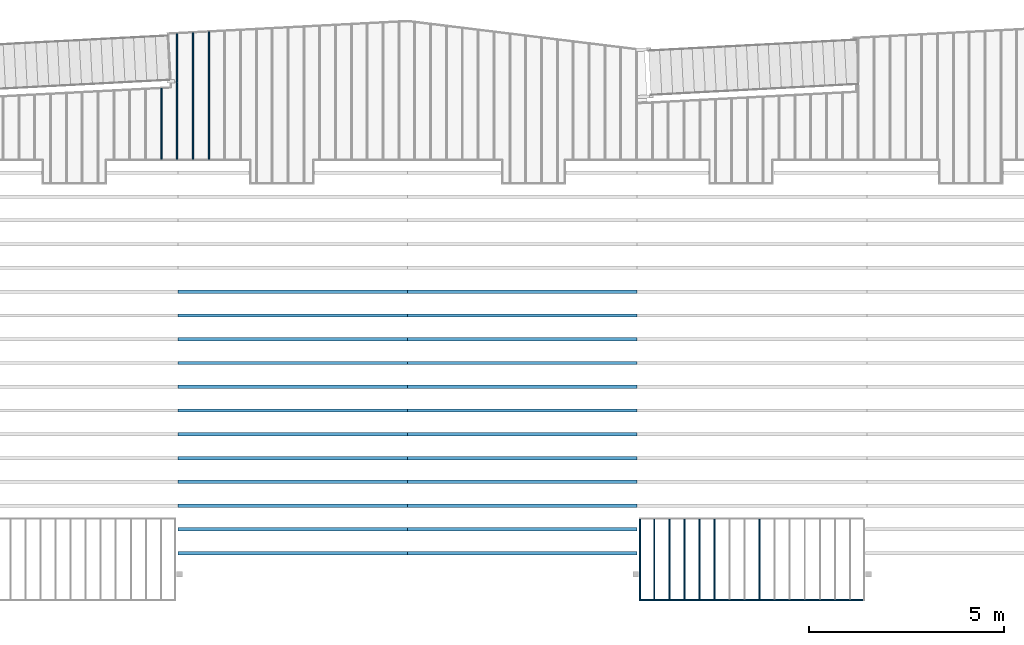
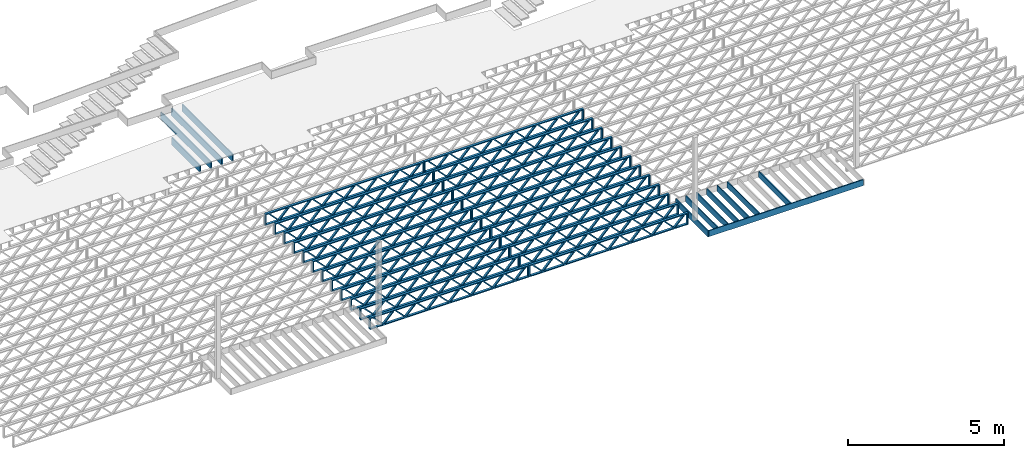
# One storey, part 6 of 23: 36 beams, 4 elements without a shape of their own.
"""IFC4 building model written with IfcOpenShell, lengths in feet."""

import ifcopenshell
import ifcopenshell.guid

model = None  # the IFC model being written
_history = None  # IfcOwnerHistory: only IFC2X3 demands one
_inside = {}  # id of a spatial element -> (the spatial element, [elements in it])
_under = {}  # id of a project, library or spatial element -> (it, [spatial elements below it])
_declared = {}  # id of a project -> (the project, [libraries it declares])
_typed = {}  # id of a type object -> (the type object, [elements of that type])
_made_of = {}  # id of a material, layer set ... -> (it, [elements and type objects made of it])


def new_model(schema):
    """Start an empty IFC model of exactly this schema.

    Asked for "IFC4X3", IfcOpenShell would pick the latest addendum, in which some entities
    have other attributes; the version numbers below select the first issue.
    IFC2X3 requires an IfcOwnerHistory on every rooted entity: one is made here for all.
    """
    global model, _history
    if schema == "IFC4X3":
        model = ifcopenshell.file(schema_version=(4, 3, 0, 0))
    else:
        model = ifcopenshell.file(schema=schema)
    _inside.clear()
    _under.clear()
    _declared.clear()
    _typed.clear()
    _made_of.clear()
    _history = None
    if model.schema == "IFC2X3":
        org = make("IfcOrganization", Name="unknown")
        user = make(
            "IfcPersonAndOrganization",
            ThePerson=make("IfcPerson", FamilyName="unknown"),
            TheOrganization=org,
        )
        app = make(
            "IfcApplication",
            ApplicationDeveloper=org,
            Version="unknown",
            ApplicationFullName="unknown",
            ApplicationIdentifier="unknown",
        )
        _history = make(
            "IfcOwnerHistory",
            OwningUser=user,
            OwningApplication=app,
            ChangeAction="ADDED",
            CreationDate=0,
        )
    return model


def make(cls, **values):
    """One entity of the class cls with the attributes given. An attribute that is None is left unset."""
    return model.create_entity(
        cls, **{name: value for name, value in values.items() if value is not None}
    )


def entity(cls, *values):
    """Any entity or typed value of the class cls, its attributes in the order of the schema. None: left unset."""
    e = model.create_entity(cls)
    for i, value in enumerate(values):
        if value is not None:
            e[i] = value
    return e


def rooted(cls, **values):
    """An entity with a GlobalId (a new one), such as an element, a storey or a relation."""
    return make(cls, GlobalId=ifcopenshell.guid.new(), OwnerHistory=_history, **values)


def si_unit(unit_type, name, prefix=None):
    """IfcSIUnit, for example si_unit("LENGTHUNIT", "METRE", prefix="MILLI")."""
    return make("IfcSIUnit", UnitType=unit_type, Prefix=prefix, Name=name)


def converted_unit(unit_type, name, factor, base, dimensions=None, offset=None):
    """IfcConversionBasedUnit, such as the inch: factor (a typed value) times the base unit."""
    return make(
        "IfcConversionBasedUnit"
        if offset is None
        else "IfcConversionBasedUnitWithOffset",
        ConversionOffset=offset,
        Dimensions=None
        if dimensions is None
        else entity("IfcDimensionalExponents", *dimensions),
        UnitType=unit_type,
        Name=name,
        ConversionFactor=make(
            "IfcMeasureWithUnit", ValueComponent=factor, UnitComponent=base
        ),
    )


def derived_unit(unit_type, elements):
    """IfcDerivedUnit: a product of units, each with its exponent."""
    return make(
        "IfcDerivedUnit",
        Elements=[
            make("IfcDerivedUnitElement", Unit=unit, Exponent=power)
            for unit, power in elements
        ],
        UnitType=unit_type,
    )


def assignment(units):
    """IfcUnitAssignment: the units of a project."""
    return None if units is None else make("IfcUnitAssignment", Units=units)


def point(xyz):
    """IfcCartesianPoint."""
    return None if xyz is None else make("IfcCartesianPoint", Coordinates=xyz)


def direction(xyz):
    """IfcDirection."""
    return None if xyz is None else make("IfcDirection", DirectionRatios=xyz)


def frame(location, z_axis=None, x_axis=None):
    """IfcAxis2Placement3D, a coordinate frame: its origin and axes. An axis left out is left unset."""
    return make(
        "IfcAxis2Placement3D",
        Location=point(location),
        Axis=direction(z_axis),
        RefDirection=direction(x_axis),
    )


def frame_2d(location, x_axis=None):
    """IfcAxis2Placement2D, a coordinate frame in the plane: its origin and x axis."""
    return make(
        "IfcAxis2Placement2D", Location=point(location), RefDirection=direction(x_axis)
    )


def origin():
    """The frame at (0, 0, 0) with its axes left unset."""
    return frame((0.0, 0.0, 0.0))


def origin_2d_with_axis():
    """The frame at (0, 0) in the plane with the x axis (1, 0) written out."""
    return frame_2d((0.0, 0.0), x_axis=(1.0, 0.0))


def place(relative_to, where):
    """IfcLocalPlacement: puts the frame where relative to a parent placement (None: the world)."""
    return make(
        "IfcLocalPlacement", PlacementRelTo=relative_to, RelativePlacement=where
    )


def context(
    kind, dimensions, precision=None, world=None, true_north=None, identifier=None
):
    """IfcGeometricRepresentationContext, for example the 3D "Model" context."""
    return make(
        "IfcGeometricRepresentationContext",
        ContextIdentifier=identifier,
        ContextType=kind,
        CoordinateSpaceDimension=dimensions,
        Precision=precision,
        WorldCoordinateSystem=world,
        TrueNorth=true_north,
    )


def subcontext(parent, identifier, kind, view, scale=None):
    """IfcGeometricRepresentationSubContext, for example "Body" below "Model"."""
    return make(
        "IfcGeometricRepresentationSubContext",
        ContextIdentifier=identifier,
        ContextType=kind,
        ParentContext=parent,
        TargetScale=scale,
        TargetView=view,
    )


def project(units=None, contexts=None):
    """IfcProject with its units and contexts."""
    return rooted(
        "IfcProject",
        Name="project",
        RepresentationContexts=contexts,
        UnitsInContext=assignment(units),
    )


def spatial(cls, under=None, at=None, **own):
    """A site, building, storey or space (cls), placed at a placement, below another one or the project."""
    s = rooted(cls, ObjectPlacement=at, **own)
    if under is not None:
        _under.setdefault(under.id(), (under, []))[1].append(s)
    return s


def profile(cls, at=None, kind="AREA", **sizes):
    """A parametric profile (cls). Its sizes go by their IFC names, for example OverallWidth=200.0."""
    return make(cls, ProfileType=kind, Position=at, **sizes)


def rectangle(**sizes):
    """IfcRectangleProfileDef."""
    return profile("IfcRectangleProfileDef", **sizes)


def extrude(swept, where, along, depth):
    """IfcExtrudedAreaSolid: the profile swept, set in the frame where, extruded along a direction by depth."""
    return make(
        "IfcExtrudedAreaSolid",
        SweptArea=swept,
        Position=where,
        ExtrudedDirection=direction(along),
        Depth=depth,
    )


def shape(context_of_items, identifier, shape_type, items):
    """IfcShapeRepresentation: the items that make up one representation, for example the "Body"."""
    return make(
        "IfcShapeRepresentation",
        ContextOfItems=context_of_items,
        RepresentationIdentifier=identifier,
        RepresentationType=shape_type,
        Items=items,
    )


def source(mapping_origin, context_of_items, identifier, shape_type, items):
    """IfcRepresentationMap: a shape defined once, which mapped items show again and again."""
    return make(
        "IfcRepresentationMap",
        MappingOrigin=mapping_origin,
        MappedRepresentation=shape(context_of_items, identifier, shape_type, items),
    )


def transform(
    local_origin,
    x_axis=None,
    y_axis=None,
    z_axis=None,
    scale=None,
    scale2=None,
    scale3=None,
    uniform=True,
):
    """IfcCartesianTransformationOperator3D, or its non-uniform kind. x_axis, y_axis, z_axis: its Axis1, 2, 3."""
    if uniform:
        return make(
            "IfcCartesianTransformationOperator3D",
            Axis1=direction(x_axis),
            Axis2=direction(y_axis),
            LocalOrigin=point(local_origin),
            Scale=scale,
            Axis3=direction(z_axis),
        )
    return make(
        "IfcCartesianTransformationOperator3DnonUniform",
        Axis1=direction(x_axis),
        Axis2=direction(y_axis),
        LocalOrigin=point(local_origin),
        Scale=scale,
        Axis3=direction(z_axis),
        Scale2=scale2,
        Scale3=scale3,
    )


def mapped(mapping_source, mapping_target):
    """IfcMappedItem: shows the shape of a source again, moved by a transform."""
    return make(
        "IfcMappedItem", MappingSource=mapping_source, MappingTarget=mapping_target
    )


def material(Name=None, Category=None):
    """IfcMaterial."""
    return make("IfcMaterial", Name=Name, Category=Category)


def material_profile(
    of_material, cross_section, Name=None, Category=None, Priority=None
):
    """IfcMaterialProfile: a cross section and its material."""
    return make(
        "IfcMaterialProfile",
        Name=Name,
        Material=of_material,
        Profile=cross_section,
        Priority=Priority,
        Category=Category,
    )


def profile_set(profiles, Name=None, composite=None):
    """IfcMaterialProfileSet."""
    return make(
        "IfcMaterialProfileSet",
        Name=Name,
        MaterialProfiles=profiles,
        CompositeProfile=composite,
    )


def profile_usage(for_profile_set, cardinal=None, extent=None):
    """IfcMaterialProfileSetUsage: how a profile set lies along its element."""
    return make(
        "IfcMaterialProfileSetUsage",
        ForProfileSet=for_profile_set,
        CardinalPoint=cardinal,
        ReferenceExtent=extent,
    )


def made_of(thing, what):
    """Note that an element or type object is made of a material, layer set ...; save() writes the relation."""
    if what is not None:
        _made_of.setdefault(what.id(), (what, []))[1].append(thing)
    return thing


def type_object(cls, material=None, **own):
    """A type object (cls), such as IfcWallType, which elements share."""
    return made_of(rooted(cls, **own), material)


def type_shapes(of_type, sources):
    """Give a type object the sources (RepresentationMaps) that its elements show as mapped items."""
    of_type.RepresentationMaps = sources


def element(
    cls,
    number,
    at=None,
    inside=None,
    cuts=None,
    type_object=None,
    material=None,
    context=None,
    identifier="Body",
    shape_type=None,
    held_by="IfcProductDefinitionShape",
    body=None,
    shapes=None,
    **own,
):
    """One element of the class cls, such as IfcWall. Its Tag is "e" and its number.

    at: its placement. inside: the storey or other place that contains it. cuts: it is an
    opening in that element (IfcRelVoidsElement). A single representation is given by context,
    identifier, shape_type and body (its items); several are given by shapes. held_by: the class
    of the entity that holds the representations. save() writes the other relations.
    """
    e = rooted(cls, Tag="e%d" % number, ObjectPlacement=at, **own)
    if body is not None:
        shapes = [shape(context, identifier, shape_type, body)]
    if shapes is not None:
        e.Representation = make(held_by, Representations=shapes)
    if inside is not None:
        _inside.setdefault(inside.id(), (inside, []))[1].append(e)
    if cuts is not None:
        rooted(
            "IfcRelVoidsElement", RelatingBuildingElement=cuts, RelatedOpeningElement=e
        )
    if type_object is not None:
        _typed.setdefault(type_object.id(), (type_object, []))[1].append(e)
    return made_of(e, material)


def aggregate(whole, parts):
    """IfcRelAggregates: a whole, such as a stair, and the parts it consists of."""
    return rooted("IfcRelAggregates", RelatingObject=whole, RelatedObjects=parts)


def save(model, path):
    """Write the relations noted so far, then the file.

    IfcRelAggregates (storeys below a building ...), IfcRelContainedInSpatialStructure (elements
    in a storey), IfcRelDefinesByType, IfcRelAssociatesMaterial and IfcRelDeclares: one each for
    every whole, place, type object, material and project.
    """
    for whole, parts in _under.values():
        aggregate(whole, parts)
    for where, things in _inside.values():
        rooted(
            "IfcRelContainedInSpatialStructure",
            RelatedElements=things,
            RelatingStructure=where,
        )
    for kind, things in _typed.values():
        rooted("IfcRelDefinesByType", RelatedObjects=things, RelatingType=kind)
    for what, things in _made_of.values():
        rooted("IfcRelAssociatesMaterial", RelatedObjects=things, RelatingMaterial=what)
    for by, libraries in _declared.values():
        rooted("IfcRelDeclares", RelatingContext=by, RelatedDefinitions=libraries)
    model.write(path)


model = new_model("IFC4")

# Units and contexts
model_context = context("Model", 3, precision=0.0001, world=origin(), true_north=direction((6.12303176911189e-17, 1.0)))
body_context = subcontext(model_context, "Body", "Model", "MODEL_VIEW")
ifc_project = project(units=[converted_unit("LENGTHUNIT", "FOOT", entity("IfcRatioMeasure", 0.3048), si_unit("LENGTHUNIT", "METRE"), dimensions=[1, 0, 0, 0, 0, 0, 0]), converted_unit("AREAUNIT", "SQUARE FOOT", entity("IfcRatioMeasure", 0.09290304), si_unit("AREAUNIT", "SQUARE_METRE"), dimensions=[2, 0, 0, 0, 0, 0, 0]), converted_unit("VOLUMEUNIT", "CUBIC FOOT", entity("IfcRatioMeasure", 0.028316846592), si_unit("VOLUMEUNIT", "CUBIC_METRE"), dimensions=[3, 0, 0, 0, 0, 0, 0]), converted_unit("PLANEANGLEUNIT", "DEGREE", entity("IfcRatioMeasure", 0.0174532925199433), si_unit("PLANEANGLEUNIT", "RADIAN"), dimensions=[0, 0, 0, 0, 0, 0, 0]), si_unit("MASSUNIT", "GRAM", prefix="KILO"), derived_unit("MASSDENSITYUNIT", [(si_unit("MASSUNIT", "GRAM", prefix="KILO"), 1), (si_unit("LENGTHUNIT", "METRE"), -3)]), derived_unit("MOMENTOFINERTIAUNIT", [(si_unit("LENGTHUNIT", "METRE"), 4)]), si_unit("TIMEUNIT", "SECOND"), si_unit("FREQUENCYUNIT", "HERTZ"), si_unit("THERMODYNAMICTEMPERATUREUNIT", "DEGREE_CELSIUS"), derived_unit("THERMALTRANSMITTANCEUNIT", [(si_unit("MASSUNIT", "GRAM", prefix="KILO"), 1), (si_unit("THERMODYNAMICTEMPERATUREUNIT", "KELVIN"), -1), (si_unit("TIMEUNIT", "SECOND"), -3)]), derived_unit("VOLUMETRICFLOWRATEUNIT", [(si_unit("LENGTHUNIT", "METRE"), 3), (si_unit("TIMEUNIT", "SECOND"), -1)]), si_unit("ELECTRICCURRENTUNIT", "AMPERE"), si_unit("ELECTRICVOLTAGEUNIT", "VOLT"), si_unit("POWERUNIT", "WATT"), si_unit("FORCEUNIT", "NEWTON"), si_unit("ILLUMINANCEUNIT", "LUX"), si_unit("LUMINOUSFLUXUNIT", "LUMEN"), si_unit("LUMINOUSINTENSITYUNIT", "CANDELA"), derived_unit("USERDEFINED", [(si_unit("MASSUNIT", "GRAM", prefix="KILO"), -1), (si_unit("LENGTHUNIT", "METRE"), -2), (si_unit("TIMEUNIT", "SECOND"), 3), (si_unit("LUMINOUSFLUXUNIT", "LUMEN"), 1)]), derived_unit("LINEARVELOCITYUNIT", [(si_unit("LENGTHUNIT", "METRE"), 1), (si_unit("TIMEUNIT", "SECOND"), -1)]), si_unit("PRESSUREUNIT", "PASCAL"), derived_unit("USERDEFINED", [(si_unit("LENGTHUNIT", "METRE"), -2), (si_unit("MASSUNIT", "GRAM", prefix="KILO"), 1), (si_unit("TIMEUNIT", "SECOND"), -2)]), derived_unit("LINEARFORCEUNIT", [(si_unit("MASSUNIT", "GRAM", prefix="KILO"), 1), (si_unit("LENGTHUNIT", "METRE"), 1), (si_unit("TIMEUNIT", "SECOND"), -2), (si_unit("LENGTHUNIT", "METRE"), -1)]), derived_unit("PLANARFORCEUNIT", [(si_unit("MASSUNIT", "GRAM", prefix="KILO"), 1), (si_unit("LENGTHUNIT", "METRE"), 1), (si_unit("TIMEUNIT", "SECOND"), -2), (si_unit("LENGTHUNIT", "METRE"), -2)])], contexts=[model_context])

# Site, building, storey
site_placement = place(None, origin())
site = spatial("IfcSite", under=ifc_project, at=site_placement, CompositionType="ELEMENT")
building_placement = place(site_placement, origin())
building = spatial("IfcBuilding", under=site, at=building_placement, CompositionType="ELEMENT")
storey_placement = place(building_placement, frame((0.0, 0.0, 10.8020833333333)))
storey = spatial("IfcBuildingStorey", under=building, at=storey_placement, Name="2ND FLOOR", CompositionType="ELEMENT", Elevation=10.8020833333333)

# Assembly, beams
assembly_1_placement = place(storey_placement, origin())
assembly_1 = element("IfcElementAssembly", 1, at=assembly_1_placement, inside=storey, Name="Structural Beam System:Structural Framing System", ObjectType="Structural Beam System:Structural Framing System", AssemblyPlace="NOTDEFINED", PredefinedType="BEAM_GRID")
ifc_material_1 = material(Category="Materials")
ifc_material_profile_1 = material_profile(ifc_material_1, rectangle(XDim=0.770833333333333, YDim=0.124999999999994, at=frame_2d((-5.55111512312578e-17, 0.0), x_axis=(1.0, 0.0))))
ifc_profile_set_1 = profile_set([ifc_material_profile_1])
ifc_profile_usage_1 = profile_usage(ifc_profile_set_1, cardinal=8)
beam_type_1 = type_object("IfcBeamType", PredefinedType="BEAM", material=ifc_profile_set_1)
shared_shape_1 = source(origin(), body_context, "Body", "SweptSolid", [
    extrude(rectangle(XDim=0.770833333333333, YDim=0.124999999999994, at=frame_2d((-5.55111512312578e-17, 0.0), x_axis=(1.0, 0.0))), frame((-3.35416666666737, 0.0, 0.0), z_axis=(1.0, 0.0, 0.0), x_axis=(0.0, 0.0, -1.0)), (0.0, 0.0, 1.0), 6.70833333333462),
])
type_shapes(beam_type_1, [shared_shape_1])
beam_1_placement = place(assembly_1_placement, frame((-173.43642510598, 925.341101549317, -0.645833333333471), z_axis=(0.0, 0.0, 1.0), x_axis=(0.0, 1.0, 0.0)))
beam_1 = element("IfcBeam", 2, at=beam_1_placement, type_object=beam_type_1, material=ifc_profile_usage_1, PredefinedType="BEAM", context=body_context, shape_type="MappedRepresentation", body=[
    mapped(shared_shape_1, transform((0.0, 0.0, 0.0), scale=1.0)),
])
ifc_profile_usage_2 = profile_usage(ifc_profile_set_1, cardinal=8)
beam_2_placement = place(assembly_1_placement, frame((-177.237076147655, 925.341101549318, -0.645833333333471), z_axis=(0.0, 0.0, 1.0), x_axis=(0.0, 1.0, 0.0)))
beam_2 = element("IfcBeam", 3, at=beam_2_placement, type_object=beam_type_1, material=ifc_profile_usage_2, PredefinedType="BEAM", context=body_context, shape_type="MappedRepresentation", body=[
    mapped(shared_shape_1, transform((0.0, 0.0, 0.0), scale=1.0)),
])
ifc_profile_usage_3 = profile_usage(ifc_profile_set_1, cardinal=8)
beam_3_placement = place(assembly_1_placement, frame((-178.503959828213, 925.341101549318, -0.645833333333471), z_axis=(0.0, 0.0, 1.0), x_axis=(0.0, 1.0, 0.0)))
beam_3 = element("IfcBeam", 4, at=beam_3_placement, type_object=beam_type_1, material=ifc_profile_usage_3, PredefinedType="BEAM", context=body_context, shape_type="MappedRepresentation", body=[
    mapped(shared_shape_1, transform((0.0, 0.0, 0.0), scale=1.0)),
])
ifc_profile_usage_4 = profile_usage(ifc_profile_set_1, cardinal=8)
beam_4_placement = place(assembly_1_placement, frame((-179.770843508771, 925.341101549318, -0.645833333333471), z_axis=(0.0, 0.0, 1.0), x_axis=(0.0, 1.0, 0.0)))
beam_4 = element("IfcBeam", 5, at=beam_4_placement, type_object=beam_type_1, material=ifc_profile_usage_4, PredefinedType="BEAM", context=body_context, shape_type="MappedRepresentation", body=[
    mapped(shared_shape_1, transform((0.0, 0.0, 0.0), scale=1.0)),
])
ifc_profile_usage_5 = profile_usage(ifc_profile_set_1, cardinal=8)
beam_5_placement = place(assembly_1_placement, frame((-181.03772718933, 925.341101549318, -0.645833333333471), z_axis=(0.0, 0.0, 1.0), x_axis=(0.0, 1.0, 0.0)))
beam_5 = element("IfcBeam", 6, at=beam_5_placement, type_object=beam_type_1, material=ifc_profile_usage_5, PredefinedType="BEAM", context=body_context, shape_type="MappedRepresentation", body=[
    mapped(shared_shape_1, transform((0.0, 0.0, 0.0), scale=1.0)),
])
ifc_profile_usage_6 = profile_usage(ifc_profile_set_1, cardinal=8)
beam_6_placement = place(assembly_1_placement, frame((-182.304610869888, 925.341101549319, -0.645833333333471), z_axis=(0.0, 0.0, 1.0), x_axis=(0.0, 1.0, 0.0)))
beam_6 = element("IfcBeam", 7, at=beam_6_placement, type_object=beam_type_1, material=ifc_profile_usage_6, PredefinedType="BEAM", context=body_context, shape_type="MappedRepresentation", body=[
    mapped(shared_shape_1, transform((0.0, 0.0, 0.0), scale=1.0)),
])
aggregate(assembly_1, [beam_1, beam_2, beam_3, beam_4, beam_5, beam_6])

assembly_2_placement = place(storey_placement, origin())
assembly_2 = element("IfcElementAssembly", 8, at=assembly_2_placement, inside=storey, Name="Structural Beam System:Structural Framing System", ObjectType="Structural Beam System:Structural Framing System", AssemblyPlace="NOTDEFINED", PredefinedType="BEAM_GRID")
ifc_material_2 = material(Name="WOOD TRUSS", Category="Materials")
ifc_material_profile_2 = material_profile(ifc_material_2, rectangle(XDim=1.73473973950632, YDim=0.125, at=frame_2d((-1.11022302462516e-16, 8.32667268468867e-17), x_axis=(1.0, 0.0))))
ifc_material_profile_3 = material_profile(ifc_material_2, rectangle(XDim=1.73473973950633, YDim=0.125, at=frame_2d((-1.11022302462516e-16, 8.32667268468867e-17), x_axis=(1.0, 0.0))))
ifc_material_profile_4 = material_profile(ifc_material_2, rectangle(XDim=1.73473973950632, YDim=0.125, at=frame_2d((-5.55111512312578e-17, 1.38777878078145e-16), x_axis=(1.0, 0.0))))
ifc_material_profile_5 = material_profile(ifc_material_2, rectangle(XDim=1.73473973950633, YDim=0.125, at=frame_2d((-1.11022302462516e-16, 8.32667268468867e-17), x_axis=(1.0, 0.0))))
ifc_material_profile_6 = material_profile(ifc_material_2, rectangle(XDim=1.73473973950632, YDim=0.125, at=frame_2d((-1.11022302462516e-16, 8.32667268468867e-17), x_axis=(1.0, 0.0))))
ifc_material_profile_7 = material_profile(ifc_material_2, rectangle(XDim=1.73473973950633, YDim=0.125, at=frame_2d((-2.77555756156289e-16, 3.05311331771918e-16), x_axis=(1.0, 0.0))))
ifc_material_profile_8 = material_profile(ifc_material_2, rectangle(XDim=1.73473973950632, YDim=0.124999999999999, at=frame_2d((-3.88578058618805e-16, -2.4980018054066e-16), x_axis=(1.0, 0.0))))
ifc_material_profile_9 = material_profile(ifc_material_2, rectangle(XDim=1.73473973950633, YDim=0.125, at=frame_2d((2.77555756156289e-16, -3.05311331771918e-16), x_axis=(1.0, 0.0))))
ifc_material_profile_10 = material_profile(ifc_material_2, rectangle(XDim=1.73473973950632, YDim=0.124999999999999, at=frame_2d((-1.11022302462516e-16, 8.32667268468867e-17), x_axis=(1.0, 0.0))))
ifc_material_profile_11 = material_profile(ifc_material_2, rectangle(XDim=1.73473973950633, YDim=0.125, at=origin_2d_with_axis()))
ifc_material_profile_12 = material_profile(ifc_material_2, rectangle(XDim=0.124999999999982, YDim=0.291666666666668, at=origin_2d_with_axis()))
ifc_material_profile_13 = material_profile(ifc_material_2, rectangle(XDim=0.124999999999932, YDim=0.291666666666664, at=origin_2d_with_axis()))
ifc_material_profile_14 = material_profile(ifc_material_2, rectangle(XDim=1.25000000000002, YDim=0.29166666666667, at=origin_2d_with_axis()))
ifc_material_profile_15 = material_profile(ifc_material_2, rectangle(XDim=1.25000000000004, YDim=0.291666666666667, at=origin_2d_with_axis()))
ifc_profile_set_2 = profile_set([ifc_material_profile_2, ifc_material_profile_3, ifc_material_profile_4, ifc_material_profile_5, ifc_material_profile_6, ifc_material_profile_7, ifc_material_profile_8, ifc_material_profile_9, ifc_material_profile_10, ifc_material_profile_11, ifc_material_profile_12, ifc_material_profile_13, ifc_material_profile_14, ifc_material_profile_15])
ifc_profile_usage_7 = profile_usage(ifc_profile_set_2, cardinal=8)
beam_type_2 = type_object("IfcBeamType", PredefinedType="BEAM", material=ifc_profile_set_2)
shared_shape_2 = source(origin(), body_context, "Body", "SweptSolid", [
    extrude(rectangle(XDim=1.73473973950632, YDim=0.124999999999999, at=frame_2d((5.55111512312578e-16, 7.21644966006352e-16), x_axis=(1.0, 0.0))), frame((5.95847627016997, -0.145833333333334, 0.0), z_axis=(0.0, 1.0, 0.0), x_axis=(0.693383046997606, 0.0, 0.720569184836762)), (0.0, 0.0, 1.0), 0.291666666666667),
    extrude(rectangle(XDim=1.73473973950633, YDim=0.125, at=origin_2d_with_axis()), frame((4.7081903964967, -0.145833333333334, 0.0), z_axis=(0.0, 1.0, 0.0), x_axis=(0.69338304699761, 0.0, -0.720569184836758)), (0.0, 0.0, 1.0), 0.291666666666666),
    extrude(rectangle(XDim=1.73473973950632, YDim=0.125, at=frame_2d((2.22044604925031e-16, 3.88578058618805e-16), x_axis=(1.0, 0.0))), frame((3.29180960350347, -0.145833333333334, 0.0), z_axis=(0.0, 1.0, 0.0), x_axis=(0.693383046997606, 0.0, 0.720569184836762)), (0.0, 0.0, 1.0), 0.291666666666667),
    extrude(rectangle(XDim=1.73473973950633, YDim=0.125, at=frame_2d((1.11022302462516e-16, -8.32667268468867e-17), x_axis=(1.0, 0.0))), frame((2.0415237298302, -0.145833333333334, 0.0), z_axis=(0.0, 1.0, 0.0), x_axis=(0.69338304699761, 0.0, -0.720569184836758)), (0.0, 0.0, 1.0), 0.291666666666667),
    extrude(rectangle(XDim=1.73473973950632, YDim=0.125, at=frame_2d((-5.55111512312578e-17, 1.38777878078145e-16), x_axis=(1.0, 0.0))), frame((0.625142936836964, -0.145833333333334, 0.0), z_axis=(0.0, 1.0, 0.0), x_axis=(0.693383046997606, 0.0, 0.720569184836762)), (0.0, 0.0, 1.0), 0.291666666666667),
    extrude(rectangle(XDim=1.73473973950633, YDim=0.125, at=frame_2d((-1.11022302462516e-16, 8.32667268468867e-17), x_axis=(1.0, 0.0))), frame((-0.625142936836306, -0.145833333333334, 0.0), z_axis=(0.0, 1.0, 0.0), x_axis=(0.69338304699761, 0.0, -0.720569184836758)), (0.0, 0.0, 1.0), 0.291666666666667),
    extrude(rectangle(XDim=1.73473973950632, YDim=0.125, at=frame_2d((-1.11022302462516e-16, 8.32667268468867e-17), x_axis=(1.0, 0.0))), frame((-2.04152372982954, -0.145833333333334, 0.0), z_axis=(0.0, 1.0, 0.0), x_axis=(0.693383046997606, 0.0, 0.720569184836762)), (0.0, 0.0, 1.0), 0.291666666666667),
    extrude(rectangle(XDim=1.73473973950633, YDim=0.125, at=origin_2d_with_axis()), frame((-3.29180960350281, -0.145833333333334, 0.0), z_axis=(0.0, 1.0, 0.0), x_axis=(0.69338304699761, 0.0, -0.720569184836758)), (0.0, 0.0, 1.0), 0.291666666666667),
    extrude(rectangle(XDim=1.73473973950632, YDim=0.124999999999999, at=frame_2d((-1.11022302462516e-16, 8.32667268468867e-17), x_axis=(1.0, 0.0))), frame((-4.70819039649604, -0.145833333333334, 0.0), z_axis=(0.0, 1.0, 0.0), x_axis=(0.693383046997606, 0.0, 0.720569184836762)), (0.0, 0.0, 1.0), 0.291666666666667),
    extrude(rectangle(XDim=1.73473973950633, YDim=0.125, at=frame_2d((-5.55111512312578e-16, 6.38378239159465e-16), x_axis=(1.0, 0.0))), frame((-5.95847627016931, -0.145833333333334, 0.0), z_axis=(0.0, 1.0, 0.0), x_axis=(0.69338304699761, 0.0, -0.720569184836758)), (0.0, 0.0, 1.0), 0.291666666666666),
    extrude(rectangle(XDim=1.73473973950632, YDim=0.125, at=frame_2d((-7.21644966006352e-16, -5.82867087928207e-16), x_axis=(1.0, 0.0))), frame((8.62514293683647, -0.145833333333334, 0.0), z_axis=(0.0, 1.0, 0.0), x_axis=(0.693383046997607, 0.0, 0.720569184836761)), (0.0, 0.0, 1.0), 0.291666666666667),
    extrude(rectangle(XDim=1.73473973950633, YDim=0.125, at=origin_2d_with_axis()), frame((7.3748570631632, -0.145833333333334, 0.0), z_axis=(0.0, 1.0, 0.0), x_axis=(0.69338304699761, 0.0, -0.720569184836758)), (0.0, 0.0, 1.0), 0.291666666666666),
    extrude(rectangle(XDim=1.73473973950632, YDim=0.124999999999999, at=frame_2d((-1.11022302462516e-16, 8.32667268468867e-17), x_axis=(1.0, 0.0))), frame((-7.37485706316255, -0.145833333333334, 0.0), z_axis=(0.0, 1.0, 0.0), x_axis=(0.693383046997606, 0.0, 0.720569184836762)), (0.0, 0.0, 1.0), 0.291666666666667),
    extrude(rectangle(XDim=1.73473973950633, YDim=0.125, at=origin_2d_with_axis()), frame((-8.62514293683582, -0.145833333333334, 0.0), z_axis=(0.0, 1.0, 0.0), x_axis=(0.69338304699761, 0.0, -0.720569184836758)), (0.0, 0.0, 1.0), 0.291666666666666),
    extrude(rectangle(XDim=0.124999999999982, YDim=0.291666666666668, at=origin_2d_with_axis()), frame((-9.66666666666609, 0.0, 0.687500000000054), z_axis=(1.0, 0.0, 0.0), x_axis=(0.0, 0.0, -1.0)), (0.0, 0.0, 1.0), 19.3333333333322),
    extrude(rectangle(XDim=0.124999999999932, YDim=0.291666666666664, at=origin_2d_with_axis()), frame((-9.66666666666588, 0.0, -0.687499999999984), z_axis=(1.0, 0.0, 0.0), x_axis=(0.0, 0.0, -1.0)), (0.0, 0.0, 1.0), 19.333333333332),
    extrude(rectangle(XDim=1.25000000000002, YDim=0.29166666666667, at=origin_2d_with_axis()), frame((9.54166666666607, 0.0, 0.0), z_axis=(1.0, 0.0, 0.0), x_axis=(0.0, 0.0, -1.0)), (0.0, 0.0, 1.0), 0.12500000000002),
    extrude(rectangle(XDim=1.25000000000004, YDim=0.291666666666667, at=origin_2d_with_axis()), frame((-9.66666666666609, 0.0, 0.0), z_axis=(1.0, 0.0, 0.0), x_axis=(0.0, 0.0, -1.0)), (0.0, 0.0, 1.0), 0.125000000000023),
])
type_shapes(beam_type_2, [shared_shape_2])
beam_7_placement = place(assembly_2_placement, frame((-193.404827152229, 947.861934882651, -0.947916666666881)))
beam_7 = element("IfcBeam", 9, at=beam_7_placement, type_object=beam_type_2, material=ifc_profile_usage_7, PredefinedType="BEAM", context=body_context, shape_type="MappedRepresentation", body=[
    mapped(shared_shape_2, transform((0.0, 0.0, 0.0), scale=1.0)),
])
ifc_profile_usage_8 = profile_usage(ifc_profile_set_2, cardinal=8)
beam_8_placement = place(assembly_2_placement, frame((-193.404827152229, 945.861934882651, -0.947916666666881)))
beam_8 = element("IfcBeam", 10, at=beam_8_placement, type_object=beam_type_2, material=ifc_profile_usage_8, PredefinedType="BEAM", context=body_context, shape_type="MappedRepresentation", body=[
    mapped(shared_shape_2, transform((0.0, 0.0, 0.0), scale=1.0)),
])
ifc_profile_usage_9 = profile_usage(ifc_profile_set_2, cardinal=8)
beam_9_placement = place(assembly_2_placement, frame((-193.404827152229, 943.861934882651, -0.947916666666881)))
beam_9 = element("IfcBeam", 11, at=beam_9_placement, type_object=beam_type_2, material=ifc_profile_usage_9, PredefinedType="BEAM", context=body_context, shape_type="MappedRepresentation", body=[
    mapped(shared_shape_2, transform((0.0, 0.0, 0.0), scale=1.0)),
])
ifc_profile_usage_10 = profile_usage(ifc_profile_set_2, cardinal=8)
beam_10_placement = place(assembly_2_placement, frame((-193.404827152229, 941.861934882651, -0.947916666666881)))
beam_10 = element("IfcBeam", 12, at=beam_10_placement, type_object=beam_type_2, material=ifc_profile_usage_10, PredefinedType="BEAM", context=body_context, shape_type="MappedRepresentation", body=[
    mapped(shared_shape_2, transform((0.0, 0.0, 0.0), scale=1.0)),
])
ifc_profile_usage_11 = profile_usage(ifc_profile_set_2, cardinal=8)
beam_11_placement = place(assembly_2_placement, frame((-193.404827152229, 939.861934882651, -0.947916666666881)))
beam_11 = element("IfcBeam", 13, at=beam_11_placement, type_object=beam_type_2, material=ifc_profile_usage_11, PredefinedType="BEAM", context=body_context, shape_type="MappedRepresentation", body=[
    mapped(shared_shape_2, transform((0.0, 0.0, 0.0), scale=1.0)),
])
ifc_profile_usage_12 = profile_usage(ifc_profile_set_2, cardinal=8)
beam_12_placement = place(assembly_2_placement, frame((-193.404827152229, 937.861934882651, -0.947916666666881)))
beam_12 = element("IfcBeam", 14, at=beam_12_placement, type_object=beam_type_2, material=ifc_profile_usage_12, PredefinedType="BEAM", context=body_context, shape_type="MappedRepresentation", body=[
    mapped(shared_shape_2, transform((0.0, 0.0, 0.0), scale=1.0)),
])
ifc_profile_usage_13 = profile_usage(ifc_profile_set_2, cardinal=8)
beam_13_placement = place(assembly_2_placement, frame((-193.404827152229, 935.861934882651, -0.947916666666881)))
beam_13 = element("IfcBeam", 15, at=beam_13_placement, type_object=beam_type_2, material=ifc_profile_usage_13, PredefinedType="BEAM", context=body_context, shape_type="MappedRepresentation", body=[
    mapped(shared_shape_2, transform((0.0, 0.0, 0.0), scale=1.0)),
])
ifc_profile_usage_14 = profile_usage(ifc_profile_set_2, cardinal=8)
beam_14_placement = place(assembly_2_placement, frame((-193.404827152229, 933.861934882651, -0.947916666666881)))
beam_14 = element("IfcBeam", 16, at=beam_14_placement, type_object=beam_type_2, material=ifc_profile_usage_14, PredefinedType="BEAM", context=body_context, shape_type="MappedRepresentation", body=[
    mapped(shared_shape_2, transform((0.0, 0.0, 0.0), scale=1.0)),
])
ifc_profile_usage_15 = profile_usage(ifc_profile_set_2, cardinal=8)
beam_15_placement = place(assembly_2_placement, frame((-193.404827152229, 931.861934882651, -0.947916666666881)))
beam_15 = element("IfcBeam", 17, at=beam_15_placement, type_object=beam_type_2, material=ifc_profile_usage_15, PredefinedType="BEAM", context=body_context, shape_type="MappedRepresentation", body=[
    mapped(shared_shape_2, transform((0.0, 0.0, 0.0), scale=1.0)),
])
ifc_profile_usage_16 = profile_usage(ifc_profile_set_2, cardinal=8)
beam_16_placement = place(assembly_2_placement, frame((-193.404827152229, 929.861934882651, -0.947916666666881)))
beam_16 = element("IfcBeam", 18, at=beam_16_placement, type_object=beam_type_2, material=ifc_profile_usage_16, PredefinedType="BEAM", context=body_context, shape_type="MappedRepresentation", body=[
    mapped(shared_shape_2, transform((0.0, 0.0, 0.0), scale=1.0)),
])
ifc_profile_usage_17 = profile_usage(ifc_profile_set_2, cardinal=8)
beam_17_placement = place(assembly_2_placement, frame((-193.404827152229, 927.861934882651, -0.947916666666881)))
beam_17 = element("IfcBeam", 19, at=beam_17_placement, type_object=beam_type_2, material=ifc_profile_usage_17, PredefinedType="BEAM", context=body_context, shape_type="MappedRepresentation", body=[
    mapped(shared_shape_2, transform((0.0, 0.0, 0.0), scale=1.0)),
])
ifc_profile_usage_18 = profile_usage(ifc_profile_set_2, cardinal=8)
beam_18_placement = place(assembly_2_placement, frame((-193.404827152229, 925.861934882651, -0.947916666666881)))
beam_18 = element("IfcBeam", 20, at=beam_18_placement, type_object=beam_type_2, material=ifc_profile_usage_18, PredefinedType="BEAM", context=body_context, shape_type="MappedRepresentation", body=[
    mapped(shared_shape_2, transform((0.0, 0.0, 0.0), scale=1.0)),
])
aggregate(assembly_2, [beam_7, beam_8, beam_9, beam_10, beam_11, beam_12, beam_13, beam_14, beam_15, beam_16, beam_17, beam_18])

assembly_3_placement = place(storey_placement, origin())
assembly_3 = element("IfcElementAssembly", 21, at=assembly_3_placement, inside=storey, Name="Structural Beam System:Structural Framing System", ObjectType="Structural Beam System:Structural Framing System", AssemblyPlace="NOTDEFINED", PredefinedType="BEAM_GRID")
ifc_profile_usage_19 = profile_usage(ifc_profile_set_2, cardinal=8)
beam_19_placement = place(assembly_3_placement, frame((-212.738160485495, 947.861934882651, -0.947916666666881), z_axis=(0.0, 0.0, 1.0), x_axis=(-1.0, 0.0, 0.0)))
beam_19 = element("IfcBeam", 22, at=beam_19_placement, type_object=beam_type_2, material=ifc_profile_usage_19, PredefinedType="BEAM", context=body_context, shape_type="MappedRepresentation", body=[
    mapped(shared_shape_2, transform((0.0, 0.0, 0.0), scale=1.0)),
])
ifc_profile_usage_20 = profile_usage(ifc_profile_set_2, cardinal=8)
beam_20_placement = place(assembly_3_placement, frame((-212.738160485495, 945.861934882651, -0.947916666666881), z_axis=(0.0, 0.0, 1.0), x_axis=(-1.0, 0.0, 0.0)))
beam_20 = element("IfcBeam", 23, at=beam_20_placement, type_object=beam_type_2, material=ifc_profile_usage_20, PredefinedType="BEAM", context=body_context, shape_type="MappedRepresentation", body=[
    mapped(shared_shape_2, transform((0.0, 0.0, 0.0), scale=1.0)),
])
ifc_profile_usage_21 = profile_usage(ifc_profile_set_2, cardinal=8)
beam_21_placement = place(assembly_3_placement, frame((-212.738160485495, 943.861934882651, -0.947916666666881), z_axis=(0.0, 0.0, 1.0), x_axis=(-1.0, 0.0, 0.0)))
beam_21 = element("IfcBeam", 24, at=beam_21_placement, type_object=beam_type_2, material=ifc_profile_usage_21, PredefinedType="BEAM", context=body_context, shape_type="MappedRepresentation", body=[
    mapped(shared_shape_2, transform((0.0, 0.0, 0.0), scale=1.0)),
])
ifc_profile_usage_22 = profile_usage(ifc_profile_set_2, cardinal=8)
beam_22_placement = place(assembly_3_placement, frame((-212.738160485495, 941.861934882651, -0.947916666666881), z_axis=(0.0, 0.0, 1.0), x_axis=(-1.0, 0.0, 0.0)))
beam_22 = element("IfcBeam", 25, at=beam_22_placement, type_object=beam_type_2, material=ifc_profile_usage_22, PredefinedType="BEAM", context=body_context, shape_type="MappedRepresentation", body=[
    mapped(shared_shape_2, transform((0.0, 0.0, 0.0), scale=1.0)),
])
ifc_profile_usage_23 = profile_usage(ifc_profile_set_2, cardinal=8)
beam_23_placement = place(assembly_3_placement, frame((-212.738160485495, 939.861934882651, -0.947916666666881), z_axis=(0.0, 0.0, 1.0), x_axis=(-1.0, 0.0, 0.0)))
beam_23 = element("IfcBeam", 26, at=beam_23_placement, type_object=beam_type_2, material=ifc_profile_usage_23, PredefinedType="BEAM", context=body_context, shape_type="MappedRepresentation", body=[
    mapped(shared_shape_2, transform((0.0, 0.0, 0.0), scale=1.0)),
])
ifc_profile_usage_24 = profile_usage(ifc_profile_set_2, cardinal=8)
beam_24_placement = place(assembly_3_placement, frame((-212.738160485495, 937.861934882651, -0.947916666666881), z_axis=(0.0, 0.0, 1.0), x_axis=(-1.0, 0.0, 0.0)))
beam_24 = element("IfcBeam", 27, at=beam_24_placement, type_object=beam_type_2, material=ifc_profile_usage_24, PredefinedType="BEAM", context=body_context, shape_type="MappedRepresentation", body=[
    mapped(shared_shape_2, transform((0.0, 0.0, 0.0), scale=1.0)),
])
ifc_profile_usage_25 = profile_usage(ifc_profile_set_2, cardinal=8)
beam_25_placement = place(assembly_3_placement, frame((-212.738160485495, 935.861934882651, -0.947916666666881), z_axis=(0.0, 0.0, 1.0), x_axis=(-1.0, 0.0, 0.0)))
beam_25 = element("IfcBeam", 28, at=beam_25_placement, type_object=beam_type_2, material=ifc_profile_usage_25, PredefinedType="BEAM", context=body_context, shape_type="MappedRepresentation", body=[
    mapped(shared_shape_2, transform((0.0, 0.0, 0.0), scale=1.0)),
])
ifc_profile_usage_26 = profile_usage(ifc_profile_set_2, cardinal=8)
beam_26_placement = place(assembly_3_placement, frame((-212.738160485495, 933.861934882651, -0.947916666666881), z_axis=(0.0, 0.0, 1.0), x_axis=(-1.0, 0.0, 0.0)))
beam_26 = element("IfcBeam", 29, at=beam_26_placement, type_object=beam_type_2, material=ifc_profile_usage_26, PredefinedType="BEAM", context=body_context, shape_type="MappedRepresentation", body=[
    mapped(shared_shape_2, transform((0.0, 0.0, 0.0), scale=1.0)),
])
ifc_profile_usage_27 = profile_usage(ifc_profile_set_2, cardinal=8)
beam_27_placement = place(assembly_3_placement, frame((-212.738160485495, 931.861934882651, -0.947916666666881), z_axis=(0.0, 0.0, 1.0), x_axis=(-1.0, 0.0, 0.0)))
beam_27 = element("IfcBeam", 30, at=beam_27_placement, type_object=beam_type_2, material=ifc_profile_usage_27, PredefinedType="BEAM", context=body_context, shape_type="MappedRepresentation", body=[
    mapped(shared_shape_2, transform((0.0, 0.0, 0.0), scale=1.0)),
])
ifc_profile_usage_28 = profile_usage(ifc_profile_set_2, cardinal=8)
beam_28_placement = place(assembly_3_placement, frame((-212.738160485495, 929.861934882651, -0.947916666666881), z_axis=(0.0, 0.0, 1.0), x_axis=(-1.0, 0.0, 0.0)))
beam_28 = element("IfcBeam", 31, at=beam_28_placement, type_object=beam_type_2, material=ifc_profile_usage_28, PredefinedType="BEAM", context=body_context, shape_type="MappedRepresentation", body=[
    mapped(shared_shape_2, transform((0.0, 0.0, 0.0), scale=1.0)),
])
ifc_profile_usage_29 = profile_usage(ifc_profile_set_2, cardinal=8)
beam_29_placement = place(assembly_3_placement, frame((-212.738160485495, 927.861934882651, -0.947916666666881), z_axis=(0.0, 0.0, 1.0), x_axis=(-1.0, 0.0, 0.0)))
beam_29 = element("IfcBeam", 32, at=beam_29_placement, type_object=beam_type_2, material=ifc_profile_usage_29, PredefinedType="BEAM", context=body_context, shape_type="MappedRepresentation", body=[
    mapped(shared_shape_2, transform((0.0, 0.0, 0.0), scale=1.0)),
])
ifc_profile_usage_30 = profile_usage(ifc_profile_set_2, cardinal=8)
beam_30_placement = place(assembly_3_placement, frame((-212.738160485495, 925.861934882651, -0.947916666666881), z_axis=(0.0, 0.0, 1.0), x_axis=(-1.0, 0.0, 0.0)))
beam_30 = element("IfcBeam", 33, at=beam_30_placement, type_object=beam_type_2, material=ifc_profile_usage_30, PredefinedType="BEAM", context=body_context, shape_type="MappedRepresentation", body=[
    mapped(shared_shape_2, transform((0.0, 0.0, 0.0), scale=1.0)),
])
aggregate(assembly_3, [beam_19, beam_20, beam_21, beam_22, beam_23, beam_24, beam_25, beam_26, beam_27, beam_28, beam_29, beam_30])

assembly_4_placement = place(storey_placement, origin())
assembly_4 = element("IfcElementAssembly", 34, at=assembly_4_placement, inside=storey, Name="Structural Beam System:Structural Framing System", ObjectType="Structural Beam System:Structural Framing System", AssemblyPlace="NOTDEFINED", PredefinedType="BEAM_GRID")
ifc_material_profile_16 = material_profile(ifc_material_1, rectangle(XDim=0.9375, YDim=0.125000000000011, at=origin_2d_with_axis()))
ifc_profile_set_3 = profile_set([ifc_material_profile_16])
ifc_profile_usage_31 = profile_usage(ifc_profile_set_3, cardinal=8)
beam_type_3 = type_object("IfcBeamType", PredefinedType="BEAM", material=ifc_profile_set_3)
shared_shape_3 = source(origin(), body_context, "Body", "SweptSolid", [
    extrude(rectangle(XDim=0.9375, YDim=0.125000000000011, at=origin_2d_with_axis()), frame((-2.97386265030843, 0.0, 0.0), z_axis=(1.0, 0.0, 0.0), x_axis=(0.0, 0.0, -1.0)), (0.0, 0.0, 1.0), 5.94772530061687),
])
type_shapes(beam_type_3, [shared_shape_3])
beam_31_placement = place(assembly_4_placement, frame((-223.800660485462, 962.002466483765, -0.729166666666744), z_axis=(0.0, 0.0, 1.0), x_axis=(0.0, 1.0, 0.0)))
beam_31 = element("IfcBeam", 35, at=beam_31_placement, type_object=beam_type_3, material=ifc_profile_usage_31, PredefinedType="BEAM", context=body_context, shape_type="MappedRepresentation", body=[
    mapped(shared_shape_3, transform((0.0, 0.0, 0.0), scale=1.0)),
])
ifc_profile_usage_32 = profile_usage(ifc_profile_set_3, cardinal=8)
beam_type_4 = type_object("IfcBeamType", PredefinedType="BEAM", material=ifc_profile_set_3)
shared_shape_4 = source(origin(), body_context, "Body", "SweptSolid", [
    extrude(rectangle(XDim=0.9375, YDim=0.125000000000011, at=origin_2d_with_axis()), frame((-5.31404394297266, 0.0, 0.0), z_axis=(1.0, 0.0, 0.0), x_axis=(0.0, 0.0, -1.0)), (0.0, 0.0, 1.0), 10.5622266281151),
])
type_shapes(beam_type_4, [shared_shape_4])
beam_32_placement = place(assembly_4_placement, frame((-222.467327152129, 964.342647459835, -0.729166666666744), z_axis=(0.0, 0.0, 1.0), x_axis=(0.0, 1.0, 0.0)))
beam_32 = element("IfcBeam", 36, at=beam_32_placement, type_object=beam_type_4, material=ifc_profile_usage_32, PredefinedType="BEAM", context=body_context, shape_type="MappedRepresentation", body=[
    mapped(shared_shape_4, transform((0.0, 0.0, 0.0), scale=1.0)),
])
ifc_profile_usage_33 = profile_usage(ifc_profile_set_3, cardinal=8)
beam_type_5 = type_object("IfcBeamType", PredefinedType="BEAM", material=ifc_profile_set_3)
shared_shape_5 = source(origin(), body_context, "Body", "SweptSolid", [
    extrude(rectangle(XDim=0.9375, YDim=0.125000000000011, at=origin_2d_with_axis()), frame((-5.31880329353191, 0.0, 0.0), z_axis=(1.0, 0.0, 0.0), x_axis=(0.0, 0.0, -1.0)), (0.0, 0.0, 1.0), 10.6376065870638),
])
type_shapes(beam_type_5, [shared_shape_5])
beam_33_placement = place(assembly_4_placement, frame((-221.133993818795, 964.3474064934, -0.729166666666744), z_axis=(0.0, 0.0, 1.0), x_axis=(0.0, 1.0, 0.0)))
beam_33 = element("IfcBeam", 37, at=beam_33_placement, type_object=beam_type_5, material=ifc_profile_usage_33, PredefinedType="BEAM", context=body_context, shape_type="MappedRepresentation", body=[
    mapped(shared_shape_5, transform((0.0, 0.0, 0.0), scale=1.0)),
])
ifc_profile_usage_34 = profile_usage(ifc_profile_set_3, cardinal=8)
beam_type_6 = type_object("IfcBeamType", PredefinedType="BEAM", material=ifc_profile_set_3)
shared_shape_6 = source(origin(), body_context, "Body", "SweptSolid", [
    extrude(rectangle(XDim=0.9375, YDim=0.125000000000011, at=origin_2d_with_axis()), frame((-5.35354820779077, 0.0, 0.0), z_axis=(1.0, 0.0, 0.0), x_axis=(0.0, 0.0, -1.0)), (0.0, 0.0, 1.0), 10.7070964155815),
])
type_shapes(beam_type_6, [shared_shape_6])
beam_34_placement = place(assembly_4_placement, frame((-219.800660485462, 964.382151090665, -0.729166666666744), z_axis=(0.0, 0.0, 1.0), x_axis=(0.0, 1.0, 0.0)))
beam_34 = element("IfcBeam", 38, at=beam_34_placement, type_object=beam_type_6, material=ifc_profile_usage_34, PredefinedType="BEAM", context=body_context, shape_type="MappedRepresentation", body=[
    mapped(shared_shape_6, transform((0.0, 0.0, 0.0), scale=1.0)),
])
aggregate(assembly_4, [beam_31, beam_32, beam_33, beam_34])

# Beams
ifc_profile_usage_35 = profile_usage(ifc_profile_set_1, cardinal=8)
beam_type_7 = type_object("IfcBeamType", PredefinedType="BEAM", material=ifc_profile_set_1)
shared_shape_7 = source(origin(), body_context, "Body", "SweptSolid", [
    extrude(rectangle(XDim=0.770833333333333, YDim=0.124999999999994, at=frame_2d((-5.55111512312578e-17, 0.0), x_axis=(1.0, 0.0))), frame((-3.47916666666737, 0.0, 0.0), z_axis=(1.0, 0.0, 0.0), x_axis=(0.0, 0.0, -1.0)), (0.0, 0.0, 1.0), 6.83333333333485),
])
type_shapes(beam_type_7, [shared_shape_7])
beam_35_placement = place(storey_placement, frame((-183.5089915739, 925.341101549319, -0.645833333333512), z_axis=(0.0, 0.0, 1.0), x_axis=(0.0, 1.0, 0.0)))
element("IfcBeam", 39, at=beam_35_placement, inside=storey, type_object=beam_type_7, material=ifc_profile_usage_35, PredefinedType="BEAM", context=body_context, shape_type="MappedRepresentation", body=[
    mapped(shared_shape_7, transform((0.0, 0.0, 0.0), scale=1.0)),
])
ifc_material_3 = material(Name="BRAKE METAL FLASHING AT PERIMETER 2X LEDGER", Category="Materials")
ifc_material_profile_17 = material_profile(ifc_material_3, rectangle(XDim=0.770833333333333, YDim=0.124999999999994, at=frame_2d((-1.11022302462516e-16, 0.0), x_axis=(1.0, 0.0))), Name="BRAKE METAL FLASHING AT PERIMETER 2X LEDGER")
ifc_profile_set_4 = profile_set([ifc_material_profile_17], Name="BRAKE METAL FLASHING AT PERIMETER 2X LEDGER")
ifc_profile_usage_36 = profile_usage(ifc_profile_set_4, cardinal=8)
beam_type_8 = type_object("IfcBeamType", PredefinedType="BEAM", material=ifc_profile_set_4)
shared_shape_8 = source(origin(), body_context, "Body", "SweptSolid", [
    extrude(rectangle(XDim=0.770833333333333, YDim=0.124999999999994, at=frame_2d((-1.11022302462516e-16, 0.0), x_axis=(1.0, 0.0))), frame((-9.37499887751909, 0.0, 0.0), z_axis=(1.0, 0.0, 0.0), x_axis=(0.0, 0.0, -1.0)), (0.0, 0.0, 1.0), 18.7499977550382),
])
type_shapes(beam_type_8, [shared_shape_8])
beam_36_placement = place(storey_placement, frame((-174.071492696381, 921.92443488265, -0.645833333333494)))
element("IfcBeam", 40, at=beam_36_placement, inside=storey, type_object=beam_type_8, material=ifc_profile_usage_36, PredefinedType="BEAM", context=body_context, shape_type="MappedRepresentation", body=[
    mapped(shared_shape_8, transform((0.0, 0.0, 0.0), scale=1.0)),
])

save(model, "model.ifc")
